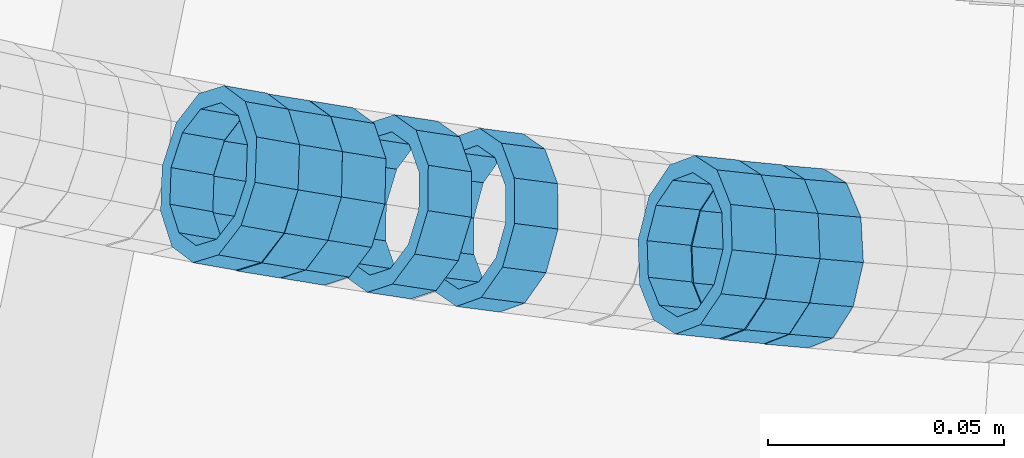
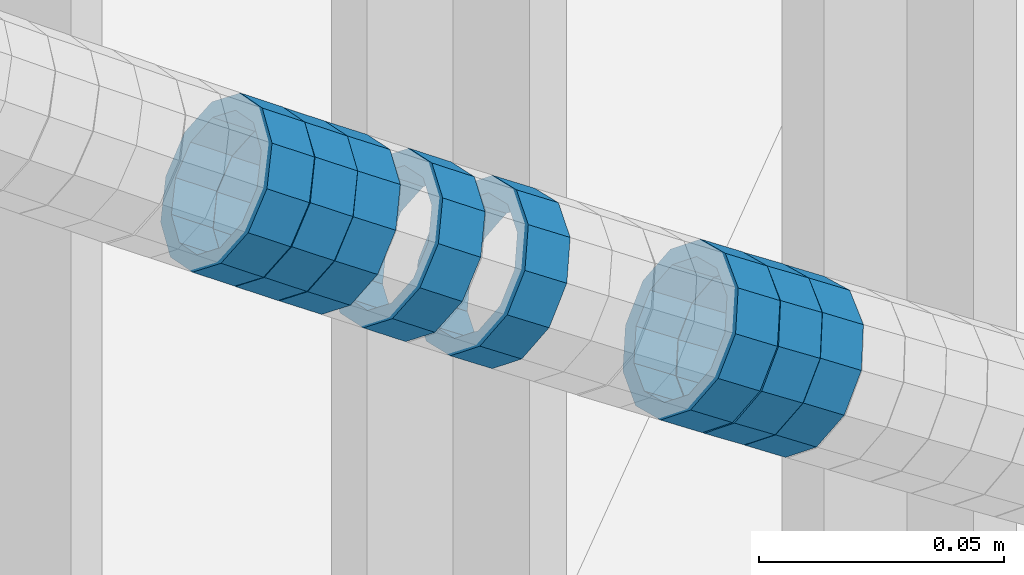
# One storey, part 685 of 975: 8 members.
"""IFC2X3 building model written with IfcOpenShell, lengths in millimetres."""

from ifc_helpers import new_model, si_unit, frame, origin_with_axes, place, context, subcontext, project, spatial, faceted_brep, material, type_object, element, save


model = new_model("IFC2X3")

# Units and contexts
model_context = context("Model", 3, precision=1e-05, world=origin_with_axes())
body_context = subcontext(model_context, "Body", "Model", "MODEL_VIEW")
ifc_project = project(units=[si_unit("LENGTHUNIT", "METRE", prefix="MILLI"), si_unit("AREAUNIT", "SQUARE_METRE"), si_unit("VOLUMEUNIT", "CUBIC_METRE"), si_unit("MASSUNIT", "GRAM", prefix="KILO"), si_unit("TIMEUNIT", "SECOND"), si_unit("PLANEANGLEUNIT", "RADIAN"), si_unit("SOLIDANGLEUNIT", "STERADIAN"), si_unit("THERMODYNAMICTEMPERATUREUNIT", "DEGREE_CELSIUS"), si_unit("LUMINOUSINTENSITYUNIT", "LUMEN")], contexts=[model_context])

# Site, building, storey
site_placement = place(None, origin_with_axes())
site = spatial("IfcSite", under=ifc_project, at=site_placement, CompositionType="ELEMENT")
building_placement = place(site_placement, origin_with_axes())
building = spatial("IfcBuilding", under=site, at=building_placement, Name="Undefined", CompositionType="ELEMENT")
storey_placement = place(building_placement, origin_with_axes())
storey = spatial("IfcBuildingStorey", under=building, at=storey_placement, Name="Undefined", CompositionType="ELEMENT", Elevation=0.0)

# Members
ifc_material = material()
member_type = type_object("IfcMemberType", PredefinedType="NOTDEFINED")
member_1_placement = place(storey_placement, frame((34483.5636621612, 1945.32689442089, 4362.42544657213), z_axis=(-0.160918642876204, -0.986967674432593, -1.19338437798433e-10), x_axis=(-0.837992726402031, 0.136629249065548, 0.528299762253473)))
element("IfcMember", 1, at=member_1_placement, inside=storey, type_object=member_type, material=ifc_material, Name="WALL", context=body_context, shape_type="Brep", body=[
    faceted_brep([(-2.1246523829177e-07, -15.367000000002, 0.0), (-1.83998054126278e-07, -13.3082123799541, 7.68350000000009), (10.9799817850508, -13.3082123799686, 7.6835000000051), (10.9799817850435, -15.3670000000202, 5.45696821063757e-12), (-1.06232619145885e-07, -7.68349999999919, 13.3082123799559), (10.9799817850653, -7.68350000000282, 13.3082123799577), (-3.63797880709171e-12, 3.63797880709171e-12, 15.3670000000002), (10.9799817850871, 1.45519152283669e-11, 15.3669999999984), (1.06225343188271e-07, 7.68350000000646, 13.3082123799559), (10.9799817851053, 7.68350000002465, 13.3082123799504), (1.8399441614747e-07, 13.308212379965, 7.68350000000009), (10.9799817851163, 13.3082123799904, 7.68349999999191), (2.12461600312963e-07, 15.3670000000093, 0.0), (10.9799817851199, 15.3670000000347, -9.09494701772928e-12), (1.8399441614747e-07, 13.308212379965, -7.68350000000009), (10.9799817851126, 13.3082123799832, -7.68350000000783), (1.06225343188271e-07, 7.68350000000646, -13.3082123799559), (10.9799817850981, 7.68350000001737, -13.3082123799613), (-3.63797880709171e-12, 3.63797880709171e-12, -15.3670000000002), (10.9799817850799, 3.63797880709171e-12, -15.367000000002), (-1.06232619145885e-07, -7.68349999999919, -13.3082123799559), (10.9799817850653, -7.68350000000646, -13.308212379955), (-1.83998054126278e-07, -13.3082123799541, -7.68350000000009), (10.9799817850508, -13.3082123799722, -7.68349999999509), (-2.63386027654633e-07, -19.0500000000029, 0.0), (-2.28097633225843e-07, -16.4977839420972, -9.52499999999964), (10.9799817850399, -16.4977839421153, -9.52499999999418), (10.9799817850362, -19.0500000000247, 6.3664629124105e-12), (-1.31691194837913e-07, -9.52500000000146, -16.4977839420935), (10.979981785058, -9.52500000001237, -16.4977839420912), (-3.63797880709171e-12, 3.63797880709171e-12, -19.0500000000002), (10.9799817850799, 0.0, -19.050000000002), (1.31687556859106e-07, 9.52500000000509, -16.4977839420935), (10.9799817851017, 9.52500000001965, -16.4977839420999), (2.28097633225843e-07, 16.4977839421044, -9.52499999999964), (10.9799817851235, 16.4977839421299, -9.5250000000101), (2.63382389675826e-07, 19.0500000000138, 0.0), (10.9799817851308, 19.0500000000393, -1.09139364212751e-11), (2.28097633225843e-07, 16.4977839421044, 9.52499999999964), (10.9799817851235, 16.4977839421335, 9.52499999999054), (1.31687556859106e-07, 9.52500000000509, 16.4977839420935), (10.979981785109, 9.52500000003056, 16.4977839420881), (-3.63797880709171e-12, 3.63797880709171e-12, 19.0500000000002), (10.9799817850871, 1.45519152283669e-11, 19.0499999999984), (-1.31691194837913e-07, -9.52500000000146, 16.4977839420935), (10.9799817850617, -9.52500000000509, 16.4977839420962), (-2.28097633225843e-07, -16.4977839420972, 9.52499999999964), (10.9799817850435, -16.4977839421117, 9.52500000000691)], [[[0, 1, 2, 3]], [[1, 4, 5, 2]], [[4, 6, 7, 5]], [[6, 8, 9, 7]], [[8, 10, 11, 9]], [[10, 12, 13, 11]], [[12, 14, 15, 13]], [[14, 16, 17, 15]], [[16, 18, 19, 17]], [[18, 20, 21, 19]], [[20, 22, 23, 21]], [[22, 0, 3, 23]], [[24, 25, 26, 27]], [[25, 28, 29, 26]], [[28, 30, 31, 29]], [[30, 32, 33, 31]], [[32, 34, 35, 33]], [[34, 36, 37, 35]], [[36, 38, 39, 37]], [[38, 40, 41, 39]], [[40, 42, 43, 41]], [[42, 44, 45, 43]], [[44, 46, 47, 45]], [[46, 24, 27, 47]], [[29, 31, 33, 35, 37, 39, 41, 43, 45, 47, 27, 26], [5, 7, 9, 11, 13, 15, 17, 19, 21, 23, 3, 2]], [[46, 44, 42, 40, 38, 36, 34, 32, 30, 28, 25, 24], [22, 20, 18, 16, 14, 12, 10, 8, 6, 4, 1, 0]]]),
])
member_2_placement = place(storey_placement, frame((34474.4457261519, 1946.93941563905, 4368.18696199119), z_axis=(-0.173167880581001, -0.984892321594135, -2.11221049539745e-10), x_axis=(-0.838220298951946, 0.147379392991552, 0.525039088969909)))
element("IfcMember", 2, at=member_2_placement, inside=storey, type_object=member_type, material=ifc_material, Name="WALL", context=body_context, shape_type="Brep", body=[
    faceted_brep([(-2.1246523829177e-07, -15.367000000002, 0.0), (-1.83998054126278e-07, -13.3082123799541, 7.68350000000009), (10.8613995415399, -13.3082123799322, 7.68349999999191), (10.8613995415435, -15.3669999999729, -8.18545231595635e-12), (-1.06232619145885e-07, -7.68349999999919, 13.3082123799559), (10.8613995415217, -7.683499999981, 13.3082123799504), (-3.63797880709171e-12, 3.63797880709171e-12, 15.3670000000002), (10.8613995415071, 3.63797880709171e-12, 15.3669999999984), (1.06225343188271e-07, 7.68350000000646, 13.3082123799559), (10.861399541478, 7.68349999998463, 13.3082123799586), (1.8399441614747e-07, 13.308212379965, 7.68350000000009), (10.8613995414671, 13.3082123799322, 7.68350000000555), (2.12461600312963e-07, 15.3670000000093, 0.0), (10.8613995414562, 15.3669999999693, 7.27595761418343e-12), (1.8399441614747e-07, 13.308212379965, -7.68350000000009), (10.8613995414671, 13.3082123799322, -7.68349999999191), (1.06225343188271e-07, 7.68350000000646, -13.3082123799559), (10.861399541478, 7.683499999981, -13.3082123799513), (-3.63797880709171e-12, 3.63797880709171e-12, -15.3670000000002), (10.8613995415035, -3.63797880709171e-12, -15.3670000000002), (-1.06232619145885e-07, -7.68349999999919, -13.3082123799559), (10.8613995415253, -7.68349999998827, -13.3082123799586), (-1.83998054126278e-07, -13.3082123799541, -7.68350000000009), (10.8613995415435, -13.3082123799286, -7.68350000000828), (-2.63386027654633e-07, -19.0500000000029, 0.0), (-2.28097633225843e-07, -16.4977839420972, -9.52499999999964), (10.8613995415471, -16.4977839420717, -9.52500000000782), (10.8613995415581, -19.0499999999629, -1.09139364212751e-11), (-1.31691194837913e-07, -9.52500000000146, -16.4977839420935), (10.861399541529, -9.5249999999869, -16.4977839420972), (-3.63797880709171e-12, 3.63797880709171e-12, -19.0500000000002), (10.8613995415035, -7.27595761418343e-12, -19.0499999999984), (1.31687556859106e-07, 9.52500000000509, -16.4977839420935), (10.861399541478, 9.52499999997963, -16.497783942089), (2.28097633225843e-07, 16.4977839421044, -9.52499999999964), (10.8613995414526, 16.4977839420644, -9.52499999999236), (2.63382389675826e-07, 19.0500000000138, 0.0), (10.8613995414489, 19.0499999999665, 8.18545231595635e-12), (2.28097633225843e-07, 16.4977839421044, 9.52499999999964), (10.8613995414598, 16.4977839420644, 9.52500000000691), (1.31687556859106e-07, 9.52500000000509, 16.4977839420935), (10.8613995414744, 9.5249999999869, 16.4977839420972), (-3.63797880709171e-12, 3.63797880709171e-12, 19.0500000000002), (10.8613995414998, 3.63797880709171e-12, 19.0499999999993), (-1.31691194837913e-07, -9.52500000000146, 16.4977839420935), (10.861399541529, -9.52499999997599, 16.4977839420862), (-2.28097633225843e-07, -16.4977839420972, 9.52499999999964), (10.8613995415508, -16.4977839420644, 9.52499999999145)], [[[0, 1, 2, 3]], [[1, 4, 5, 2]], [[4, 6, 7, 5]], [[6, 8, 9, 7]], [[8, 10, 11, 9]], [[10, 12, 13, 11]], [[12, 14, 15, 13]], [[14, 16, 17, 15]], [[16, 18, 19, 17]], [[18, 20, 21, 19]], [[20, 22, 23, 21]], [[22, 0, 3, 23]], [[24, 25, 26, 27]], [[25, 28, 29, 26]], [[28, 30, 31, 29]], [[30, 32, 33, 31]], [[32, 34, 35, 33]], [[34, 36, 37, 35]], [[36, 38, 39, 37]], [[38, 40, 41, 39]], [[40, 42, 43, 41]], [[42, 44, 45, 43]], [[44, 46, 47, 45]], [[46, 24, 27, 47]], [[29, 31, 33, 35, 37, 39, 41, 43, 45, 47, 27, 26], [5, 7, 9, 11, 13, 15, 17, 19, 21, 23, 3, 2]], [[46, 44, 42, 40, 38, 36, 34, 32, 30, 28, 25, 24], [22, 20, 18, 16, 14, 12, 10, 8, 6, 4, 1, 0]]]),
])
member_3_placement = place(storey_placement, frame((34529.508371019, 1938.19716223161, 4333.76849844361), z_axis=(-0.129339183764649, -0.991600411225759, -1.61313437274657e-10), x_axis=(-0.844890481631006, 0.110203105951872, 0.523464754771406)))
element("IfcMember", 3, at=member_3_placement, inside=storey, type_object=member_type, material=ifc_material, Name="WALL", context=body_context, shape_type="Brep", body=[
    faceted_brep([(-2.1246523829177e-07, -15.367000000002, 0.0), (-1.83998054126278e-07, -13.3082123799541, 7.68350000000009), (10.8908218239267, -13.3082123799468, 7.68349999999828), (10.8908218239521, -15.3669999999729, -6.3664629124105e-12), (-1.06232619145885e-07, -7.68349999999919, 13.3082123799559), (10.8908218238939, -7.6835000000101, 13.3082123799586), (-3.63797880709171e-12, 3.63797880709171e-12, 15.3670000000002), (10.8908218238757, -2.18278728425503e-11, 15.3670000000075), (1.06225343188271e-07, 7.68350000000646, 13.3082123799559), (10.8908218238612, 7.68349999996644, 13.308212379965), (1.8399441614747e-07, 13.308212379965, 7.68350000000009), (10.8908218238612, 13.308212379925, 7.68350000000919), (2.12461600312963e-07, 15.3670000000093, 0.0), (10.8908218238794, 15.3669999999802, 5.45696821063757e-12), (1.8399441614747e-07, 13.308212379965, -7.68350000000009), (10.8908218239012, 13.3082123799541, -7.68349999999828), (1.06225343188271e-07, 7.68350000000646, -13.3082123799559), (10.8908218239339, 7.68350000001737, -13.30821237996), (-3.63797880709171e-12, 3.63797880709171e-12, -15.3670000000002), (10.8908218239558, 3.27418092638254e-11, -15.3670000000075), (-1.06232619145885e-07, -7.68349999999919, -13.3082123799559), (10.890821823974, -7.68349999996281, -13.308212379965), (-1.83998054126278e-07, -13.3082123799541, -7.68350000000009), (10.8908218239667, -13.3082123799177, -7.68350000000919), (-2.63386027654633e-07, -19.0500000000029, 0.0), (-2.28097633225843e-07, -16.4977839420972, -9.52499999999964), (10.8908218239812, -16.4977839420499, -9.52500000001055), (10.8908218239594, -19.0499999999665, -7.73070496506989e-12), (-1.31691194837913e-07, -9.52500000000146, -16.4977839420935), (10.8908218239812, -9.52499999994689, -16.4977839421063), (-3.63797880709171e-12, 3.63797880709171e-12, -19.0500000000002), (10.8908218239703, 3.63797880709171e-11, -19.0500000000093), (1.31687556859106e-07, 9.52500000000509, -16.4977839420935), (10.8908218239412, 9.52500000002328, -16.4977839420981), (2.28097633225843e-07, 16.4977839421044, -9.52499999999964), (10.8908218239048, 16.4977839420899, -9.52499999999873), (2.63382389675826e-07, 19.0500000000138, 0.0), (10.8908218238685, 19.0499999999774, 6.82121026329696e-12), (2.28097633225843e-07, 16.4977839421044, 9.52499999999964), (10.8908218238539, 16.4977839420535, 9.525000000011), (1.31687556859106e-07, 9.52500000000509, 16.4977839420935), (10.8908218238466, 9.52499999996144, 16.4977839421058), (-3.63797880709171e-12, 3.63797880709171e-12, 19.0500000000002), (10.8908218238648, -3.27418092638254e-11, 19.0500000000097), (-1.31691194837913e-07, -9.52500000000146, 16.4977839420935), (10.8908218238939, -9.52500000000873, 16.4977839420972), (-2.28097633225843e-07, -16.4977839420972, 9.52499999999964), (10.8908218239267, -16.4977839420826, 9.52499999999873)], [[[0, 1, 2, 3]], [[1, 4, 5, 2]], [[4, 6, 7, 5]], [[6, 8, 9, 7]], [[8, 10, 11, 9]], [[10, 12, 13, 11]], [[12, 14, 15, 13]], [[14, 16, 17, 15]], [[16, 18, 19, 17]], [[18, 20, 21, 19]], [[20, 22, 23, 21]], [[22, 0, 3, 23]], [[24, 25, 26, 27]], [[25, 28, 29, 26]], [[28, 30, 31, 29]], [[30, 32, 33, 31]], [[32, 34, 35, 33]], [[34, 36, 37, 35]], [[36, 38, 39, 37]], [[38, 40, 41, 39]], [[40, 42, 43, 41]], [[42, 44, 45, 43]], [[44, 46, 47, 45]], [[46, 24, 27, 47]], [[29, 31, 33, 35, 37, 39, 41, 43, 45, 47, 27, 26], [5, 7, 9, 11, 13, 15, 17, 19, 21, 23, 3, 2]], [[46, 44, 42, 40, 38, 36, 34, 32, 30, 28, 25, 24], [22, 20, 18, 16, 14, 12, 10, 8, 6, 4, 1, 0]]]),
])
member_4_placement = place(storey_placement, frame((34594.0026962766, 1930.68512338967, 4293.6678918792), z_axis=(-0.0866296163037332, -0.996240588200997, 1.79111339093652e-10), x_axis=(-0.843646243703903, 0.0733605429742553, 0.531863935813302)))
element("IfcMember", 4, at=member_4_placement, inside=storey, type_object=member_type, material=ifc_material, Name="WALL", context=body_context, shape_type="Brep", body=[
    faceted_brep([(-2.1246523829177e-07, -15.367000000002, 0.0), (-1.83998054126278e-07, -13.3082123799541, 7.68350000000009), (10.9055031979988, -13.3082123799322, 7.68349999999873), (10.9055031979988, -15.3669999999729, -1.81898940354586e-12), (-1.06232619145885e-07, -7.68349999999919, 13.3082123799559), (10.9055031979842, -7.683499999981, 13.3082123799552), (-3.63797880709171e-12, 3.63797880709171e-12, 15.3670000000002), (10.9055031979697, 7.27595761418343e-12, 15.3670000000002), (1.06225343188271e-07, 7.68350000000646, 13.3082123799559), (10.9055031979478, 7.68349999999191, 13.3082123799561), (1.8399441614747e-07, 13.308212379965, 7.68350000000009), (10.9055031979333, 13.3082123799395, 7.68350000000078), (2.12461600312963e-07, 15.3670000000093, 0.0), (10.9055031979187, 15.3669999999802, 4.54747350886464e-13), (1.8399441614747e-07, 13.308212379965, -7.68350000000009), (10.9055031979187, 13.3082123799395, -7.68350000000009), (1.06225343188271e-07, 7.68350000000646, -13.3082123799559), (10.9055031979296, 7.68349999999191, -13.3082123799561), (-3.63797880709171e-12, 3.63797880709171e-12, -15.3670000000002), (10.9055031979478, 3.63797880709171e-12, -15.3670000000013), (-1.06232619145885e-07, -7.68349999999919, -13.3082123799559), (10.9055031979697, -7.683499999981, -13.3082123799575), (-1.83998054126278e-07, -13.3082123799541, -7.68350000000009), (10.9055031979842, -13.3082123799286, -7.68350000000214), (-2.63386027654633e-07, -19.0500000000029, 0.0), (-2.28097633225843e-07, -16.4977839420972, -9.52499999999964), (10.9055031979879, -16.4977839420681, -9.52500000000214), (10.9055031980097, -19.0499999999629, -2.04636307898909e-12), (-1.31691194837913e-07, -9.52500000000146, -16.4977839420935), (10.9055031979624, -9.52499999998327, -16.4977839420956), (-3.63797880709171e-12, 3.63797880709171e-12, -19.0500000000002), (10.9055031979406, 3.63797880709171e-12, -19.0500000000015), (1.31687556859106e-07, 9.52500000000509, -16.4977839420935), (10.9055031979151, 9.5249999999869, -16.4977839420942), (2.28097633225843e-07, 16.4977839421044, -9.52499999999964), (10.9055031979115, 16.4977839420717, -9.52499999999986), (2.63382389675826e-07, 19.0500000000138, 0.0), (10.9055031979115, 19.0499999999774, 6.82121026329696e-13), (2.28097633225843e-07, 16.4977839421044, 9.52499999999964), (10.9055031979296, 16.4977839420753, 9.52500000000123), (1.31687556859106e-07, 9.52500000000509, 16.4977839420935), (10.9055031979515, 9.52499999999054, 16.4977839420942), (-3.63797880709171e-12, 3.63797880709171e-12, 19.0500000000002), (10.9055031979733, 7.27595761418343e-12, 19.0500000000004), (-1.31691194837913e-07, -9.52500000000146, 16.4977839420935), (10.9055031979988, -9.52499999997599, 16.4977839420933), (-2.28097633225843e-07, -16.4977839420972, 9.52499999999964), (10.905503198006, -16.4977839420644, 9.52499999999873)], [[[0, 1, 2, 3]], [[1, 4, 5, 2]], [[4, 6, 7, 5]], [[6, 8, 9, 7]], [[8, 10, 11, 9]], [[10, 12, 13, 11]], [[12, 14, 15, 13]], [[14, 16, 17, 15]], [[16, 18, 19, 17]], [[18, 20, 21, 19]], [[20, 22, 23, 21]], [[22, 0, 3, 23]], [[24, 25, 26, 27]], [[25, 28, 29, 26]], [[28, 30, 31, 29]], [[30, 32, 33, 31]], [[32, 34, 35, 33]], [[34, 36, 37, 35]], [[36, 38, 39, 37]], [[38, 40, 41, 39]], [[40, 42, 43, 41]], [[42, 44, 45, 43]], [[44, 46, 47, 45]], [[46, 24, 27, 47]], [[29, 31, 33, 35, 37, 39, 41, 43, 45, 47, 27, 26], [5, 7, 9, 11, 13, 15, 17, 19, 21, 23, 3, 2]], [[46, 44, 42, 40, 38, 36, 34, 32, 30, 28, 25, 24], [22, 20, 18, 16, 14, 12, 10, 8, 6, 4, 1, 0]]]),
])
member_5_placement = place(storey_placement, frame((34511.0350535024, 1940.92328104608, 4345.23299991046), z_axis=(-0.150441997419031, -0.988618837273786, 2.32518686971161e-10), x_axis=(-0.839002670976915, 0.127674319996493, 0.528936466985437)))
element("IfcMember", 5, at=member_5_placement, inside=storey, type_object=member_type, material=ifc_material, Name="WALL", context=body_context, shape_type="Brep", body=[
    faceted_brep([(-2.1246523829177e-07, -15.367000000002, 0.0), (-1.83998054126278e-07, -13.3082123799541, 7.68350000000009), (10.9726933794955, -13.3082123799577, 7.68349999999873), (10.9726933795027, -15.3669999999984, -3.18323145620525e-12), (-1.06232619145885e-07, -7.68349999999919, 13.3082123799559), (10.9726933794846, -7.6835000000101, 13.308212379955), (-3.63797880709171e-12, 3.63797880709171e-12, 15.3670000000002), (10.9726933794773, -1.09139364212751e-11, 15.3670000000011), (1.06225343188271e-07, 7.68350000000646, 13.3082123799559), (10.9726933794773, 7.68349999998827, 13.3082123799563), (1.8399441614747e-07, 13.308212379965, 7.68350000000009), (10.9726933794846, 13.3082123799504, 7.68350000000146), (2.12461600312963e-07, 15.3670000000093, 0.0), (10.9726933794882, 15.3669999999984, 9.09494701772928e-13), (1.8399441614747e-07, 13.308212379965, -7.68350000000009), (10.9726933794955, 13.3082123799613, -7.68350000000055), (1.06225343188271e-07, 7.68350000000646, -13.3082123799559), (10.97269337951, 7.68350000001374, -13.3082123799572), (-3.63797880709171e-12, 3.63797880709171e-12, -15.3670000000002), (10.97269337951, 1.09139364212751e-11, -15.3670000000029), (-1.06232619145885e-07, -7.68349999999919, -13.3082123799559), (10.9726933795137, -7.68349999998463, -13.3082123799586), (-1.83998054126278e-07, -13.3082123799541, -7.68350000000009), (10.9726933795064, -13.3082123799468, -7.68350000000328), (-2.63386027654633e-07, -19.0500000000029, 0.0), (-2.28097633225843e-07, -16.4977839420972, -9.52499999999964), (10.97269337951, -16.4977839420826, -9.52500000000418), (10.9726933795027, -19.0499999999993, -2.27373675443232e-12), (-1.31691194837913e-07, -9.52500000000146, -16.4977839420935), (10.9726933795137, -9.52499999998327, -16.4977839420976), (-3.63797880709171e-12, 3.63797880709171e-12, -19.0500000000002), (10.9726933795209, 1.81898940354586e-11, -19.0500000000034), (1.31687556859106e-07, 9.52500000000509, -16.4977839420935), (10.97269337951, 9.52500000001237, -16.4977839420958), (2.28097633225843e-07, 16.4977839421044, -9.52499999999964), (10.9726933795027, 16.4977839421008, -9.525000000001), (2.63382389675826e-07, 19.0500000000138, 0.0), (10.9726933794882, 19.0499999999993, 4.54747350886464e-13), (2.28097633225843e-07, 16.4977839421044, 9.52499999999964), (10.9726933794809, 16.4977839420826, 9.52500000000236), (1.31687556859106e-07, 9.52500000000509, 16.4977839420935), (10.97269337947, 9.5249999999869, 16.4977839420967), (-3.63797880709171e-12, 3.63797880709171e-12, 19.0500000000002), (10.9726933794736, -1.81898940354586e-11, 19.0500000000015), (-1.31691194837913e-07, -9.52500000000146, 16.4977839420935), (10.9726933794809, -9.52500000001237, 16.4977839420931), (-2.28097633225843e-07, -16.4977839420972, 9.52499999999964), (10.9726933794882, -16.4977839420972, 9.52499999999827)], [[[0, 1, 2, 3]], [[1, 4, 5, 2]], [[4, 6, 7, 5]], [[6, 8, 9, 7]], [[8, 10, 11, 9]], [[10, 12, 13, 11]], [[12, 14, 15, 13]], [[14, 16, 17, 15]], [[16, 18, 19, 17]], [[18, 20, 21, 19]], [[20, 22, 23, 21]], [[22, 0, 3, 23]], [[24, 25, 26, 27]], [[25, 28, 29, 26]], [[28, 30, 31, 29]], [[30, 32, 33, 31]], [[32, 34, 35, 33]], [[34, 36, 37, 35]], [[36, 38, 39, 37]], [[38, 40, 41, 39]], [[40, 42, 43, 41]], [[42, 44, 45, 43]], [[44, 46, 47, 45]], [[46, 24, 27, 47]], [[29, 31, 33, 35, 37, 39, 41, 43, 45, 47, 27, 26], [5, 7, 9, 11, 13, 15, 17, 19, 21, 23, 3, 2]], [[46, 44, 42, 40, 38, 36, 34, 32, 30, 28, 25, 24], [22, 20, 18, 16, 14, 12, 10, 8, 6, 4, 1, 0]]]),
])
member_6_placement = place(storey_placement, frame((34585.0216530781, 1931.56303279198, 4299.33733118072), z_axis=(-0.0963241951590171, -0.995350013526381, 1.2438977137208e-10), x_axis=(-0.849713789370503, 0.0822303670358537, 0.520792322227171)))
element("IfcMember", 6, at=member_6_placement, inside=storey, type_object=member_type, material=ifc_material, Name="WALL", context=body_context, shape_type="Brep", body=[
    faceted_brep([(-2.1246523829177e-07, -15.367000000002, 0.0), (-1.83998054126278e-07, -13.3082123799541, 7.68350000000009), (10.9448618081915, -13.3082123799541, 7.68349999999987), (10.944861808206, -15.3669999999875, -1.81898940354586e-12), (-1.06232619145885e-07, -7.68349999999919, 13.3082123799559), (10.9448618081733, -7.68350000000282, 13.3082123799568), (-3.63797880709171e-12, 3.63797880709171e-12, 15.3670000000002), (10.944861808166, -1.09139364212751e-11, 15.3670000000025), (1.06225343188271e-07, 7.68350000000646, 13.3082123799559), (10.9448618081624, 7.68349999998827, 13.3082123799586), (1.8399441614747e-07, 13.308212379965, 7.68350000000009), (10.9448618081697, 13.3082123799468, 7.68350000000214), (2.12461600312963e-07, 15.3670000000093, 0.0), (10.9448618081842, 15.3669999999984, 2.27373675443232e-13), (1.8399441614747e-07, 13.308212379965, -7.68350000000009), (10.9448618082024, 13.3082123799613, -7.68350000000123), (1.06225343188271e-07, 7.68350000000646, -13.3082123799559), (10.944861808217, 7.68350000001374, -13.3082123799586), (-3.63797880709171e-12, 3.63797880709171e-12, -15.3670000000002), (10.9448618082242, 1.45519152283669e-11, -15.3670000000036), (-1.06232619145885e-07, -7.68349999999919, -13.3082123799559), (10.9448618082279, -7.68349999997736, -13.30821237996), (-1.83998054126278e-07, -13.3082123799541, -7.68350000000009), (10.9448618082242, -13.3082123799322, -7.68350000000351), (-2.63386027654633e-07, -19.0500000000029, 0.0), (-2.28097633225843e-07, -16.4977839420972, -9.52499999999964), (10.9448618082242, -16.4977839420681, -9.52500000000418), (10.9448618082097, -19.0499999999847, -2.50111042987555e-12), (-1.31691194837913e-07, -9.52500000000146, -16.4977839420935), (10.9448618082351, -9.52499999997599, -16.4977839420985), (-3.63797880709171e-12, 3.63797880709171e-12, -19.0500000000002), (10.9448618082315, 2.5465851649642e-11, -19.050000000004), (1.31687556859106e-07, 9.52500000000509, -16.4977839420935), (10.9448618082242, 9.52500000001601, -16.4977839420967), (2.28097633225843e-07, 16.4977839421044, -9.52499999999964), (10.9448618082097, 16.4977839421008, -9.52500000000146), (2.63382389675826e-07, 19.0500000000138, 0.0), (10.9448618081842, 19.049999999992, 1.13686837721616e-12), (2.28097633225843e-07, 16.4977839421044, 9.52499999999964), (10.944861808166, 16.4977839420826, 9.52500000000259), (1.31687556859106e-07, 9.52500000000509, 16.4977839420935), (10.9448618081624, 9.52499999998327, 16.4977839420972), (-3.63797880709171e-12, 3.63797880709171e-12, 19.0500000000002), (10.9448618081587, -1.09139364212751e-11, 19.0500000000031), (-1.31691194837913e-07, -9.52500000000146, 16.4977839420935), (10.9448618081697, -9.52500000000873, 16.4977839420953), (-2.28097633225843e-07, -16.4977839420972, 9.52499999999964), (10.9448618081915, -16.4977839420899, 9.52499999999941)], [[[0, 1, 2, 3]], [[1, 4, 5, 2]], [[4, 6, 7, 5]], [[6, 8, 9, 7]], [[8, 10, 11, 9]], [[10, 12, 13, 11]], [[12, 14, 15, 13]], [[14, 16, 17, 15]], [[16, 18, 19, 17]], [[18, 20, 21, 19]], [[20, 22, 23, 21]], [[22, 0, 3, 23]], [[24, 25, 26, 27]], [[25, 28, 29, 26]], [[28, 30, 31, 29]], [[30, 32, 33, 31]], [[32, 34, 35, 33]], [[34, 36, 37, 35]], [[36, 38, 39, 37]], [[38, 40, 41, 39]], [[40, 42, 43, 41]], [[42, 44, 45, 43]], [[44, 46, 47, 45]], [[46, 24, 27, 47]], [[29, 31, 33, 35, 37, 39, 41, 43, 45, 47, 27, 26], [5, 7, 9, 11, 13, 15, 17, 19, 21, 23, 3, 2]], [[46, 44, 42, 40, 38, 36, 34, 32, 30, 28, 25, 24], [22, 20, 18, 16, 14, 12, 10, 8, 6, 4, 1, 0]]]),
])
member_7_placement = place(storey_placement, frame((34575.6149979378, 1932.58068346073, 4305.10994484923), z_axis=(-0.106910606307443, -0.994268636867811, 1.98312591237482e-10), x_axis=(-0.845000741023671, 0.0908602950025472, 0.526989710014813)))
element("IfcMember", 7, at=member_7_placement, inside=storey, type_object=member_type, material=ifc_material, Name="WALL", context=body_context, shape_type="Brep", body=[
    faceted_brep([(-2.1246523829177e-07, -15.367000000002, 0.0), (-1.83998054126278e-07, -13.3082123799541, 7.68350000000009), (11.011811840086, -13.308212379925, 7.683499999981), (11.0118118400642, -15.3669999999838, -9.09494701772928e-12), (-1.06232619145885e-07, -7.68349999999919, 13.3082123799559), (11.0118118400896, -7.68349999997008, 13.3082123799377), (-3.63797880709171e-12, 3.63797880709171e-12, 15.3670000000002), (11.0118118400751, 2.5465851649642e-11, 15.3669999999875), (1.06225343188271e-07, 7.68350000000646, 13.3082123799559), (11.0118118400496, 7.6835000000101, 13.3082123799504), (1.8399441614747e-07, 13.308212379965, 7.68350000000009), (11.0118118400242, 13.3082123799504, 7.68350000000646), (2.12461600312963e-07, 15.3670000000093, 0.0), (11.0118118399951, 15.3669999999765, 1.63709046319127e-11), (1.8399441614747e-07, 13.308212379965, -7.68350000000009), (11.0118118399769, 13.3082123799213, -7.68349999997736), (1.06225343188271e-07, 7.68350000000646, -13.3082123799559), (11.0118118399769, 7.68349999996644, -13.3082123799322), (-3.63797880709171e-12, 3.63797880709171e-12, -15.3670000000002), (11.0118118399841, -2.5465851649642e-11, -15.366999999982), (-1.06232619145885e-07, -7.68349999999919, -13.3082123799559), (11.011811840006, -7.68350000001737, -13.308212379945), (-1.83998054126278e-07, -13.3082123799541, -7.68350000000009), (11.0118118400424, -13.3082123799541, -7.683500000001), (-2.63386027654633e-07, -19.0500000000029, 0.0), (-2.28097633225843e-07, -16.4977839420972, -9.52499999999964), (11.0118118400424, -16.4977839420935, -9.52500000000327), (11.0118118400751, -19.0499999999738, -1.63709046319127e-11), (-1.31691194837913e-07, -9.52500000000146, -16.4977839420935), (11.011811840006, -9.52500000001601, -16.4977839420826), (-3.63797880709171e-12, 3.63797880709171e-12, -19.0500000000002), (11.0118118399732, -3.27418092638254e-11, -19.0499999999793), (1.31687556859106e-07, 9.52500000000509, -16.4977839420935), (11.0118118399623, 9.5249999999578, -16.4977839420662), (2.28097633225843e-07, 16.4977839421044, -9.52499999999964), (11.0118118399623, 16.4977839420535, -9.52499999997235), (2.63382389675826e-07, 19.0500000000138, 0.0), (11.0118118399878, 19.0499999999738, 1.81898940354586e-11), (2.28097633225843e-07, 16.4977839421044, 9.52499999999964), (11.0118118400169, 16.4977839420862, 9.52500000000691), (1.31687556859106e-07, 9.52500000000509, 16.4977839420935), (11.0118118400569, 9.52500000001601, 16.4977839420862), (-3.63797880709171e-12, 3.63797880709171e-12, 19.0500000000002), (11.011811840086, 3.63797880709171e-11, 19.0499999999811), (-1.31691194837913e-07, -9.52500000000146, 16.4977839420935), (11.0118118401006, -9.5249999999578, 16.4977839420681), (-2.28097633225843e-07, -16.4977839420972, 9.52499999999964), (11.0118118400933, -16.4977839420608, 9.52499999997781)], [[[0, 1, 2, 3]], [[1, 4, 5, 2]], [[4, 6, 7, 5]], [[6, 8, 9, 7]], [[8, 10, 11, 9]], [[10, 12, 13, 11]], [[12, 14, 15, 13]], [[14, 16, 17, 15]], [[16, 18, 19, 17]], [[18, 20, 21, 19]], [[20, 22, 23, 21]], [[22, 0, 3, 23]], [[24, 25, 26, 27]], [[25, 28, 29, 26]], [[28, 30, 31, 29]], [[30, 32, 33, 31]], [[32, 34, 35, 33]], [[34, 36, 37, 35]], [[36, 38, 39, 37]], [[38, 40, 41, 39]], [[40, 42, 43, 41]], [[42, 44, 45, 43]], [[44, 46, 47, 45]], [[46, 24, 27, 47]], [[29, 31, 33, 35, 37, 39, 41, 43, 45, 47, 27, 26], [5, 7, 9, 11, 13, 15, 17, 19, 21, 23, 3, 2]], [[46, 44, 42, 40, 38, 36, 34, 32, 30, 28, 25, 24], [22, 20, 18, 16, 14, 12, 10, 8, 6, 4, 1, 0]]]),
])
member_8_placement = place(storey_placement, frame((34492.8880149306, 1943.80661951283, 4356.64772771103), z_axis=(-0.160918642876204, -0.986967674432593, -1.19338437798433e-10), x_axis=(-0.842019288307546, 0.137285754050153, 0.521685863190613)))
element("IfcMember", 8, at=member_8_placement, inside=storey, type_object=member_type, material=ifc_material, Name="WALL", context=body_context, shape_type="Brep", body=[
    faceted_brep([(-2.1246523829177e-07, -15.367000000002, 0.0), (-1.83998054126278e-07, -13.3082123799541, 7.68350000000009), (10.9334349588862, -13.3082123799722, 7.68350000000555), (10.9334349588862, -15.3670000000166, 5.45696821063757e-12), (-1.06232619145885e-07, -7.68349999999919, 13.3082123799559), (10.9334349588826, -7.68350000001737, 13.3082123799609), (-3.63797880709171e-12, 3.63797880709171e-12, 15.3670000000002), (10.9334349588862, -1.45519152283669e-11, 15.3670000000043), (1.06225343188271e-07, 7.68350000000646, 13.3082123799559), (10.9334349588898, 7.68349999998827, 13.3082123799591), (1.8399441614747e-07, 13.308212379965, 7.68350000000009), (10.9334349588898, 13.3082123799395, 7.68350000000419), (2.12461600312963e-07, 15.3670000000093, 0.0), (10.9334349588971, 15.3669999999911, 3.63797880709171e-12), (1.8399441614747e-07, 13.308212379965, -7.68350000000009), (10.9334349588935, 13.3082123799431, -7.683499999996), (1.06225343188271e-07, 7.68350000000646, -13.3082123799559), (10.9334349588971, 7.68349999998827, -13.3082123799518), (-3.63797880709171e-12, 3.63797880709171e-12, -15.3670000000002), (10.9334349588971, -1.45519152283669e-11, -15.3669999999961), (-1.06232619145885e-07, -7.68349999999919, -13.3082123799559), (10.9334349588935, -7.68350000001737, -13.3082123799509), (-1.83998054126278e-07, -13.3082123799541, -7.68350000000009), (10.9334349588898, -13.3082123799686, -7.68349999999464), (-2.63386027654633e-07, -19.0500000000029, 0.0), (-2.28097633225843e-07, -16.4977839420972, -9.52499999999964), (10.9334349588898, -16.4977839421117, -9.52499999999372), (10.9334349588898, -19.0500000000211, 5.45696821063757e-12), (-1.31691194837913e-07, -9.52500000000146, -16.4977839420935), (10.9334349588971, -9.52500000001237, -16.4977839420885), (-3.63797880709171e-12, 3.63797880709171e-12, -19.0500000000002), (10.9334349588971, -1.09139364212751e-11, -19.0499999999961), (1.31687556859106e-07, 9.52500000000509, -16.4977839420935), (10.9334349589008, 9.52499999999054, -16.4977839420894), (2.28097633225843e-07, 16.4977839421044, -9.52499999999964), (10.9334349589008, 16.4977839420826, -9.52499999999645), (2.63382389675826e-07, 19.0500000000138, 0.0), (10.9334349588898, 19.0499999999884, 3.18323145620525e-12), (2.28097633225843e-07, 16.4977839421044, 9.52499999999964), (10.9334349588935, 16.497783942079, 9.52500000000282), (1.31687556859106e-07, 9.52500000000509, 16.4977839420935), (10.9334349588826, 9.52499999998327, 16.4977839420976), (-3.63797880709171e-12, 3.63797880709171e-12, 19.0500000000002), (10.9334349588826, -1.81898940354586e-11, 19.0500000000043), (-1.31691194837913e-07, -9.52500000000146, 16.4977839420935), (10.9334349588826, -9.52500000001965, 16.4977839420994), (-2.28097633225843e-07, -16.4977839420972, 9.52499999999964), (10.9334349588826, -16.4977839421117, 9.52500000000646)], [[[0, 1, 2, 3]], [[1, 4, 5, 2]], [[4, 6, 7, 5]], [[6, 8, 9, 7]], [[8, 10, 11, 9]], [[10, 12, 13, 11]], [[12, 14, 15, 13]], [[14, 16, 17, 15]], [[16, 18, 19, 17]], [[18, 20, 21, 19]], [[20, 22, 23, 21]], [[22, 0, 3, 23]], [[24, 25, 26, 27]], [[25, 28, 29, 26]], [[28, 30, 31, 29]], [[30, 32, 33, 31]], [[32, 34, 35, 33]], [[34, 36, 37, 35]], [[36, 38, 39, 37]], [[38, 40, 41, 39]], [[40, 42, 43, 41]], [[42, 44, 45, 43]], [[44, 46, 47, 45]], [[46, 24, 27, 47]], [[29, 31, 33, 35, 37, 39, 41, 43, 45, 47, 27, 26], [5, 7, 9, 11, 13, 15, 17, 19, 21, 23, 3, 2]], [[46, 44, 42, 40, 38, 36, 34, 32, 30, 28, 25, 24], [22, 20, 18, 16, 14, 12, 10, 8, 6, 4, 1, 0]]]),
])

save(model, "model.ifc")
